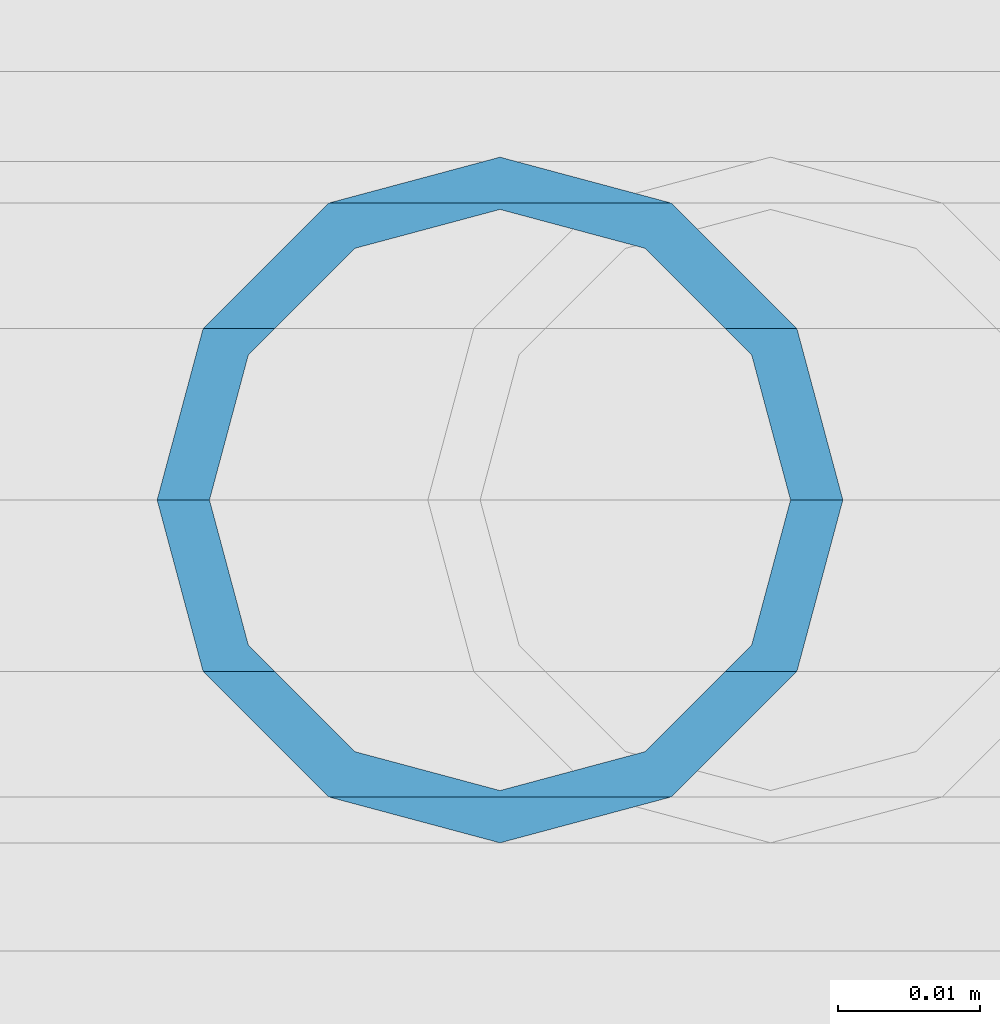
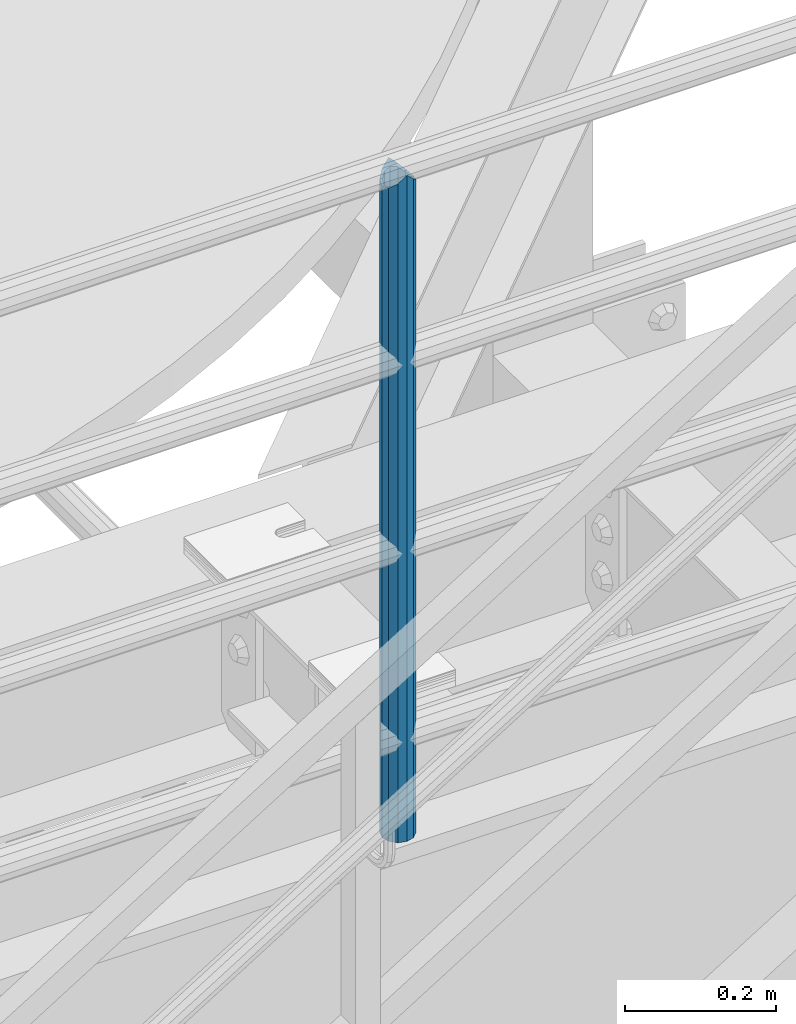
# One storey, part 635 of 1876: 1 column, 1 element without a shape of its own.
"""IFC2X3 building model written with IfcOpenShell, lengths in millimetres."""

import ifcopenshell
import ifcopenshell.guid

model = None  # the IFC model being written
_history = None  # IfcOwnerHistory: only IFC2X3 demands one
_inside = {}  # id of a spatial element -> (the spatial element, [elements in it])
_under = {}  # id of a project, library or spatial element -> (it, [spatial elements below it])
_declared = {}  # id of a project -> (the project, [libraries it declares])
_typed = {}  # id of a type object -> (the type object, [elements of that type])
_made_of = {}  # id of a material, layer set ... -> (it, [elements and type objects made of it])


def new_model(schema):
    """Start an empty IFC model of exactly this schema.

    Asked for "IFC4X3", IfcOpenShell would pick the latest addendum, in which some entities
    have other attributes; the version numbers below select the first issue.
    IFC2X3 requires an IfcOwnerHistory on every rooted entity: one is made here for all.
    """
    global model, _history
    if schema == "IFC4X3":
        model = ifcopenshell.file(schema_version=(4, 3, 0, 0))
    else:
        model = ifcopenshell.file(schema=schema)
    _inside.clear()
    _under.clear()
    _declared.clear()
    _typed.clear()
    _made_of.clear()
    _history = None
    if model.schema == "IFC2X3":
        org = make("IfcOrganization", Name="unknown")
        user = make(
            "IfcPersonAndOrganization",
            ThePerson=make("IfcPerson", FamilyName="unknown"),
            TheOrganization=org,
        )
        app = make(
            "IfcApplication",
            ApplicationDeveloper=org,
            Version="unknown",
            ApplicationFullName="unknown",
            ApplicationIdentifier="unknown",
        )
        _history = make(
            "IfcOwnerHistory",
            OwningUser=user,
            OwningApplication=app,
            ChangeAction="ADDED",
            CreationDate=0,
        )
    return model


def make(cls, **values):
    """One entity of the class cls with the attributes given. An attribute that is None is left unset."""
    return model.create_entity(
        cls, **{name: value for name, value in values.items() if value is not None}
    )


def rooted(cls, **values):
    """An entity with a GlobalId (a new one), such as an element, a storey or a relation."""
    return make(cls, GlobalId=ifcopenshell.guid.new(), OwnerHistory=_history, **values)


def si_unit(unit_type, name, prefix=None):
    """IfcSIUnit, for example si_unit("LENGTHUNIT", "METRE", prefix="MILLI")."""
    return make("IfcSIUnit", UnitType=unit_type, Prefix=prefix, Name=name)


def assignment(units):
    """IfcUnitAssignment: the units of a project."""
    return None if units is None else make("IfcUnitAssignment", Units=units)


def point(xyz):
    """IfcCartesianPoint."""
    return None if xyz is None else make("IfcCartesianPoint", Coordinates=xyz)


def direction(xyz):
    """IfcDirection."""
    return None if xyz is None else make("IfcDirection", DirectionRatios=xyz)


def frame(location, z_axis=None, x_axis=None):
    """IfcAxis2Placement3D, a coordinate frame: its origin and axes. An axis left out is left unset."""
    return make(
        "IfcAxis2Placement3D",
        Location=point(location),
        Axis=direction(z_axis),
        RefDirection=direction(x_axis),
    )


def origin_with_axes():
    """The frame at (0, 0, 0) with the z axis (0, 0, 1) and the x axis (1, 0, 0) written out."""
    return frame((0.0, 0.0, 0.0), z_axis=(0.0, 0.0, 1.0), x_axis=(1.0, 0.0, 0.0))


def place(relative_to, where):
    """IfcLocalPlacement: puts the frame where relative to a parent placement (None: the world)."""
    return make(
        "IfcLocalPlacement", PlacementRelTo=relative_to, RelativePlacement=where
    )


def context(
    kind, dimensions, precision=None, world=None, true_north=None, identifier=None
):
    """IfcGeometricRepresentationContext, for example the 3D "Model" context."""
    return make(
        "IfcGeometricRepresentationContext",
        ContextIdentifier=identifier,
        ContextType=kind,
        CoordinateSpaceDimension=dimensions,
        Precision=precision,
        WorldCoordinateSystem=world,
        TrueNorth=true_north,
    )


def subcontext(parent, identifier, kind, view, scale=None):
    """IfcGeometricRepresentationSubContext, for example "Body" below "Model"."""
    return make(
        "IfcGeometricRepresentationSubContext",
        ContextIdentifier=identifier,
        ContextType=kind,
        ParentContext=parent,
        TargetScale=scale,
        TargetView=view,
    )


def project(units=None, contexts=None):
    """IfcProject with its units and contexts."""
    return rooted(
        "IfcProject",
        Name="project",
        RepresentationContexts=contexts,
        UnitsInContext=assignment(units),
    )


def spatial(cls, under=None, at=None, **own):
    """A site, building, storey or space (cls), placed at a placement, below another one or the project."""
    s = rooted(cls, ObjectPlacement=at, **own)
    if under is not None:
        _under.setdefault(under.id(), (under, []))[1].append(s)
    return s


def faces_of(points, faces, orient=None, outer=None):
    """IfcFace entities. A face is a list of loops; a loop is a list of indices into points, from 0.

    orient and outer hold one flag for each loop. By default every Orientation is true, the
    first loop of a face is its IfcFaceOuterBound and the others are IfcFaceBound.
    """
    made = []
    for i, loops in enumerate(faces):
        bounds = []
        for j, loop in enumerate(loops):
            is_outer = j == 0 if outer is None else outer[i][j]
            bounds.append(
                make(
                    "IfcFaceOuterBound" if is_outer else "IfcFaceBound",
                    Bound=make("IfcPolyLoop", Polygon=[points[k] for k in loop]),
                    Orientation=True if orient is None else orient[i][j],
                )
            )
        made.append(make("IfcFace", Bounds=bounds))
    return made


def faceted_brep(points, faces, orient=None, outer=None, voids=None):
    """IfcFacetedBrep: a solid bounded by flat faces; with voids (closed shells), ...WithVoids."""
    shared = [point(p) for p in points]
    hull = make("IfcClosedShell", CfsFaces=faces_of(shared, faces, orient, outer))
    if voids is None:
        return make("IfcFacetedBrep", Outer=hull)
    return make(
        "IfcFacetedBrepWithVoids",
        Outer=hull,
        Voids=[
            make(cls, CfsFaces=faces_of(shared, fs, o, b)) for cls, fs, o, b in voids
        ],
    )


def shape(context_of_items, identifier, shape_type, items):
    """IfcShapeRepresentation: the items that make up one representation, for example the "Body"."""
    return make(
        "IfcShapeRepresentation",
        ContextOfItems=context_of_items,
        RepresentationIdentifier=identifier,
        RepresentationType=shape_type,
        Items=items,
    )


def material(Name=None, Category=None):
    """IfcMaterial."""
    return make("IfcMaterial", Name=Name, Category=Category)


def made_of(thing, what):
    """Note that an element or type object is made of a material, layer set ...; save() writes the relation."""
    if what is not None:
        _made_of.setdefault(what.id(), (what, []))[1].append(thing)
    return thing


def type_object(cls, material=None, **own):
    """A type object (cls), such as IfcWallType, which elements share."""
    return made_of(rooted(cls, **own), material)


def element(
    cls,
    number,
    at=None,
    inside=None,
    cuts=None,
    type_object=None,
    material=None,
    context=None,
    identifier="Body",
    shape_type=None,
    held_by="IfcProductDefinitionShape",
    body=None,
    shapes=None,
    **own,
):
    """One element of the class cls, such as IfcWall. Its Tag is "e" and its number.

    at: its placement. inside: the storey or other place that contains it. cuts: it is an
    opening in that element (IfcRelVoidsElement). A single representation is given by context,
    identifier, shape_type and body (its items); several are given by shapes. held_by: the class
    of the entity that holds the representations. save() writes the other relations.
    """
    e = rooted(cls, Tag="e%d" % number, ObjectPlacement=at, **own)
    if body is not None:
        shapes = [shape(context, identifier, shape_type, body)]
    if shapes is not None:
        e.Representation = make(held_by, Representations=shapes)
    if inside is not None:
        _inside.setdefault(inside.id(), (inside, []))[1].append(e)
    if cuts is not None:
        rooted(
            "IfcRelVoidsElement", RelatingBuildingElement=cuts, RelatedOpeningElement=e
        )
    if type_object is not None:
        _typed.setdefault(type_object.id(), (type_object, []))[1].append(e)
    return made_of(e, material)


def aggregate(whole, parts):
    """IfcRelAggregates: a whole, such as a stair, and the parts it consists of."""
    return rooted("IfcRelAggregates", RelatingObject=whole, RelatedObjects=parts)


def save(model, path):
    """Write the relations noted so far, then the file.

    IfcRelAggregates (storeys below a building ...), IfcRelContainedInSpatialStructure (elements
    in a storey), IfcRelDefinesByType, IfcRelAssociatesMaterial and IfcRelDeclares: one each for
    every whole, place, type object, material and project.
    """
    for whole, parts in _under.values():
        aggregate(whole, parts)
    for where, things in _inside.values():
        rooted(
            "IfcRelContainedInSpatialStructure",
            RelatedElements=things,
            RelatingStructure=where,
        )
    for kind, things in _typed.values():
        rooted("IfcRelDefinesByType", RelatedObjects=things, RelatingType=kind)
    for what, things in _made_of.values():
        rooted("IfcRelAssociatesMaterial", RelatedObjects=things, RelatingMaterial=what)
    for by, libraries in _declared.values():
        rooted("IfcRelDeclares", RelatingContext=by, RelatedDefinitions=libraries)
    model.write(path)


model = new_model("IFC2X3")

# Units and contexts
model_context = context("Model", 3, precision=1e-05, world=origin_with_axes())
body_context = subcontext(model_context, "Body", "Model", "MODEL_VIEW")
ifc_project = project(units=[si_unit("LENGTHUNIT", "METRE", prefix="MILLI"), si_unit("AREAUNIT", "SQUARE_METRE"), si_unit("VOLUMEUNIT", "CUBIC_METRE"), si_unit("MASSUNIT", "GRAM", prefix="KILO"), si_unit("TIMEUNIT", "SECOND"), si_unit("PLANEANGLEUNIT", "RADIAN"), si_unit("SOLIDANGLEUNIT", "STERADIAN"), si_unit("THERMODYNAMICTEMPERATUREUNIT", "DEGREE_CELSIUS"), si_unit("LUMINOUSINTENSITYUNIT", "LUMEN")], contexts=[model_context])

# Site, building, storey
site_placement = place(None, origin_with_axes())
site = spatial("IfcSite", under=ifc_project, at=site_placement, CompositionType="ELEMENT")
building_placement = place(site_placement, origin_with_axes())
building = spatial("IfcBuilding", under=site, at=building_placement, Name="Undefined", CompositionType="ELEMENT")
storey_placement = place(building_placement, origin_with_axes())
storey = spatial("IfcBuildingStorey", under=building, at=storey_placement, Name="Undefined", CompositionType="ELEMENT", Elevation=0.0)

# Assembly, column
assembly_placement = place(storey_placement, origin_with_axes())
assembly = element("IfcElementAssembly", 1, at=assembly_placement, inside=storey, Name="RAIL", AssemblyPlace="NOTDEFINED", PredefinedType="RIGID_FRAME")
ifc_material = material()
column_type = type_object("IfcColumnType", Name="PIPE1-1/2SCH40", PredefinedType="NOTDEFINED")
column_placement = place(assembly_placement, frame((5048.24999996468, -4654.55000114554, 17983.2), z_axis=(0.0, 1.0, 0.0), x_axis=(0.0, 0.0, 1.0)))
column = element("IfcColumn", 2, at=column_placement, type_object=column_type, material=ifc_material, Name="POST", ObjectType="PIPE1-1/2SCH40", context=body_context, shape_type="Brep", body=[
    faceted_brep([(1076.325, 0.0, -24.1300000000001), (1064.26, 12.065, -20.8971929933186), (1064.26, -12.0650000000001, -20.8971929933186), (1054.93437856882, 17.7076214311801, 10.2235000000001), (1052.195, 20.4470000000001, 0.0), (1052.195, 24.13, 0.0), (1055.42780700668, 20.8971929933185, 12.0649999999996), (1055.42780700668, 15.8661214311869, 12.0649999999932), (1055.42780700668, 15.8661214311742, -12.065000000006), (1055.42780700668, 20.8971929933185, -12.0649999999996), (1054.93437856882, 17.7076214311801, -10.2235000000001), (1061.07042843786, 10.2235000000001, -17.7076214311801), (1063.80980700668, 0.0, -20.4470000000001), (1061.07042843786, -10.2235000000001, -17.7076214311801), (1055.42780700668, -15.8661214311742, -12.065000000006), (1055.42780700668, -20.8971929933184, -12.0649999999996), (1054.93437856882, -17.7076214311801, -10.2235000000001), (1052.195, -20.4470000000001, 0.0), (1052.195, -24.1300000000001, 0.0), (1054.93437856882, -17.7076214311801, 10.2235000000001), (1055.42780700668, -15.8661214311869, 12.0649999999932), (1055.42780700668, -20.8971929933184, 12.0649999999996), (1076.325, 0.0, 24.1300000000001), (1064.26, -12.0650000000001, 20.8971929933186), (1064.26, 12.065, 20.8971929933186), (1061.07042843787, -10.2235000000001, 17.7076214311801), (1063.80980700669, 0.0, 20.4470000000001), (1061.07042843787, 10.2235000000001, 17.7076214311801), (0.0, -20.8971929933184, -12.0649999999996), (0.0, -12.0650000000001, -20.8971929933186), (-1.45519152283669e-11, 0.0, -24.130000000001), (0.0, 12.0650000000001, -20.8971929933186), (0.0, 20.8971929933184, -12.0649999999996), (0.0, 24.1299999999992, 0.0), (0.0, 20.8971929933184, 12.0649999999996), (0.0, 12.0650000000001, 20.8971929933186), (-1.45519152283669e-11, 0.0, 24.130000000001), (0.0, -20.8971929933184, 12.0649999999996), (0.0, -24.1299999999992, 0.0), (0.0, -12.0650000000001, 20.8971929933186), (0.0, -17.7076214311803, -10.2235000000001), (0.0, -10.2235000000001, -17.7076214311801), (-1.45519152283669e-11, 0.0, -20.4470000000001), (0.0, 10.2235000000001, -17.7076214311801), (0.0, 17.7076214311803, -10.2235000000001), (0.0, 20.4469999999999, 0.0), (0.0, 17.7076214311803, 10.2235000000001), (0.0, 10.2235000000001, 17.7076214311801), (-1.45519152283669e-11, 0.0, 20.4470000000001), (0.0, -10.2235000000001, 17.7076214311801), (0.0, -17.7076214311803, 10.2235000000001), (0.0, -20.4469999999999, 0.0)], [[[0, 1, 2]], [[3, 4, 5, 6, 7]], [[8, 9, 5, 4, 10]], [[2, 1, 9, 8, 11, 12, 13, 14, 15]], [[15, 14, 16, 17, 18]], [[18, 17, 19, 20, 21]], [[22, 23, 24]], [[21, 20, 25, 26, 27, 7, 6, 24, 23]], [[28, 29, 2, 15]], [[29, 30, 0, 2]], [[30, 31, 1, 0]], [[31, 32, 9, 1]], [[32, 33, 5, 9]], [[33, 34, 6, 5]], [[34, 35, 24, 6]], [[35, 36, 22, 24]], [[37, 38, 18, 21]], [[39, 37, 21, 23]], [[36, 39, 23, 22]], [[38, 28, 15, 18]], [[37, 39, 36, 35, 34, 33, 32, 31, 30, 29, 28, 38], [40, 41, 42, 43, 44, 45, 46, 47, 48, 49, 50, 51]], [[49, 48, 26, 25]], [[19, 50, 49, 25, 20]], [[51, 50, 19, 17]], [[40, 51, 17, 16]], [[41, 40, 16, 14, 13]], [[42, 41, 13, 12]], [[43, 42, 12, 11]], [[10, 44, 43, 11, 8]], [[45, 44, 10, 4]], [[46, 45, 4, 3]], [[47, 46, 3, 7, 27]], [[48, 47, 27, 26]]]),
])
aggregate(assembly, [column])

save(model, "model.ifc")
